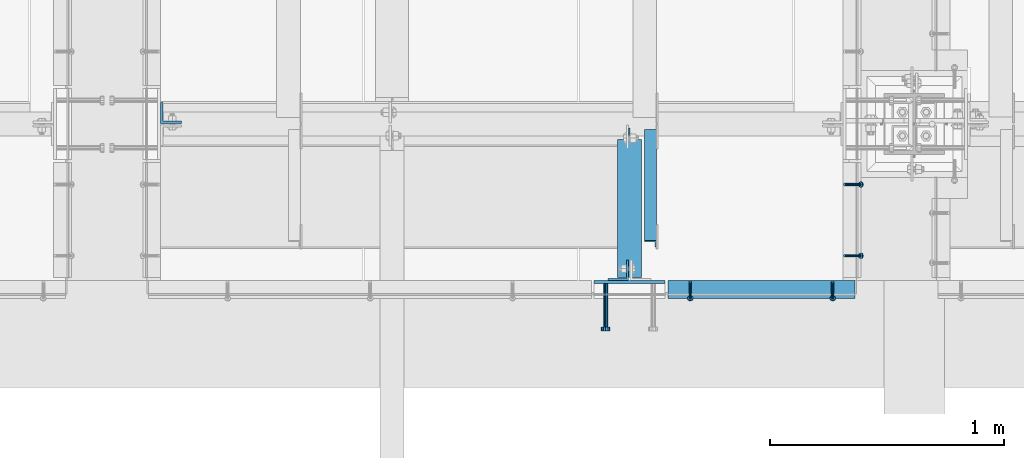
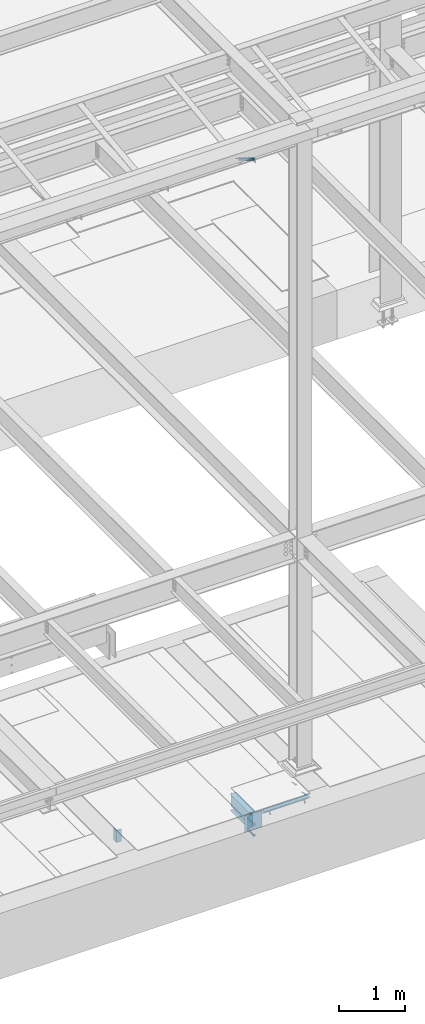
# One storey, part 2049 of 3843: 7 beams, 5 members, 6 elements without a shape of their own.
"""IFC2X3 building model written with IfcOpenShell, lengths in millimetres."""

from ifc_helpers import new_model, si_unit, frame, origin_with_axes, place, context, subcontext, project, spatial, faceted_brep, material, type_object, element, aggregate, save


model = new_model("IFC2X3")

# Units and contexts
model_context = context("Model", 3, precision=1e-05, world=origin_with_axes())
body_context = subcontext(model_context, "Body", "Model", "MODEL_VIEW")
ifc_project = project(units=[si_unit("LENGTHUNIT", "METRE", prefix="MILLI"), si_unit("AREAUNIT", "SQUARE_METRE"), si_unit("VOLUMEUNIT", "CUBIC_METRE"), si_unit("MASSUNIT", "GRAM", prefix="KILO"), si_unit("TIMEUNIT", "SECOND"), si_unit("PLANEANGLEUNIT", "RADIAN"), si_unit("SOLIDANGLEUNIT", "STERADIAN"), si_unit("THERMODYNAMICTEMPERATUREUNIT", "DEGREE_CELSIUS"), si_unit("LUMINOUSINTENSITYUNIT", "LUMEN")], contexts=[model_context])

# Site, building, storey
site_placement = place(None, origin_with_axes())
site = spatial("IfcSite", under=ifc_project, at=site_placement, CompositionType="ELEMENT")
building_placement = place(site_placement, origin_with_axes())
building = spatial("IfcBuilding", under=site, at=building_placement, Name="Undefined", CompositionType="ELEMENT")
storey_placement = place(building_placement, origin_with_axes())
storey = spatial("IfcBuildingStorey", under=building, at=storey_placement, Name="Undefined", CompositionType="ELEMENT", Elevation=0.0)

# Assembly, members
assembly_1_placement = place(storey_placement, origin_with_axes())
assembly_1 = element("IfcElementAssembly", 1, at=assembly_1_placement, inside=storey, Name="ANGLE", AssemblyPlace="NOTDEFINED", PredefinedType="RIGID_FRAME")
ifc_material_1 = material(Name="STEEL/A108")
member_type_1 = type_object("IfcMemberType", PredefinedType="NOTDEFINED")
member_1_placement = place(assembly_1_placement, frame((62337.9500047469, 14739.9375439544, 30422.8500045777), z_axis=(0.0, 1.0, 0.0), x_axis=(0.707106781186548, 0.0, -0.707106781186548)))
member_1 = element("IfcMember", 2, at=member_1_placement, type_object=member_type_1, material=ifc_material_1, Name="HEADED STUD ANCHOR", context=body_context, shape_type="Brep", body=[
    faceted_brep([(7.27595761418343e-12, -3.18000006675175, 5.5), (0.0, -5.49999999998363, 3.1800000667572), (94.4879985803855, -5.50000000011278, 3.1800000667572), (94.4879985803782, -3.18000006687362, 5.5), (0.0, -6.3499999046162, 0.0), (94.4879985803855, -6.34999990474535, 0.0), (0.0, -5.49999999998363, -3.1800000667572), (94.4879985803855, -5.50000000011278, -3.1800000667572), (7.27595761418343e-12, -3.18000006675175, -5.5), (94.4879985803782, -3.18000006687362, -5.5), (7.27595761418343e-12, -1.81898940354586e-12, -6.34999990463257), (94.4879985803782, -1.20053300634027e-10, -6.34999990463257), (0.0, 3.18000006675175, -5.5), (94.4879985803709, 3.18000006663351, -5.5), (7.27595761418343e-12, 5.49999999998363, -3.1800000667572), (94.4879985803709, 5.49999999987267, -3.1800000667572), (7.27595761418343e-12, 6.3499999046162, 0.0), (94.4879985803673, 6.34999990450706, 0.0), (7.27595761418343e-12, 5.49999999998363, 3.1800000667572), (94.4879985803709, 5.49999999987267, 3.1800000667572), (0.0, 3.18000006675175, 5.5), (94.4879985803709, 3.18000006663351, 5.5), (7.27595761418343e-12, -1.81898940354586e-12, 6.34999990463257), (94.4879985803782, -1.20053300634027e-10, 6.34999990463257), (96.5199985498621, -10.9899997712273, 6.34999990463257), (96.5199985498548, -6.34000015270249, 10.9899997711182), (96.5199985498621, -12.6999998093743, 0.0), (96.5199985498621, -10.9899997712273, -6.34999990463257), (96.5199985498548, -6.34000015270249, -10.9899997711182), (96.5199985498475, -1.21872290037572e-10, -12.6899995803833), (96.5199985498402, 6.34000015245874, -10.9899997711182), (96.519998549833, 10.9899997709817, -6.34999990463257), (96.519998549833, 12.6999998091305, 0.0), (96.519998549833, 10.9899997709817, 6.34999990463257), (96.5199985498402, 6.34000015245874, 10.9899997711182), (96.5199985498475, -1.21872290037572e-10, 12.6899995803833), (101.599998473539, -10.9899997712328, 6.34999990463257), (101.599998473532, -6.34000015270976, 10.9899997711182), (101.599998473539, -12.6999998093797, 0.0), (101.599998473539, -10.9899997712328, -6.34999990463257), (101.599998473532, -6.34000015270976, -10.9899997711182), (101.599998473524, -1.29148247651756e-10, -12.6899995803833), (101.599998473517, 6.34000015245329, -10.9899997711182), (101.59999847351, 10.9899997709763, -6.34999990463257), (101.599998473503, 12.6999998091196, 0.0), (101.59999847351, 10.9899997709763, 6.34999990463257), (101.599998473517, 6.34000015245329, 10.9899997711182), (101.599998473524, -1.29148247651756e-10, 12.6899995803833)], [[[0, 1, 2, 3]], [[1, 4, 5, 2]], [[4, 6, 7, 5]], [[6, 8, 9, 7]], [[8, 10, 11, 9]], [[10, 12, 13, 11]], [[12, 14, 15, 13]], [[14, 16, 17, 15]], [[16, 18, 19, 17]], [[18, 20, 21, 19]], [[20, 22, 23, 21]], [[22, 0, 3, 23]], [[22, 20, 18, 16, 14, 12, 10, 8, 6, 4, 1, 0]], [[3, 2, 24, 25]], [[2, 5, 26, 24]], [[5, 7, 27, 26]], [[7, 9, 28, 27]], [[9, 11, 29, 28]], [[11, 13, 30, 29]], [[13, 15, 31, 30]], [[15, 17, 32, 31]], [[17, 19, 33, 32]], [[19, 21, 34, 33]], [[21, 23, 35, 34]], [[23, 3, 25, 35]], [[25, 24, 36, 37]], [[24, 26, 38, 36]], [[26, 27, 39, 38]], [[27, 28, 40, 39]], [[28, 29, 41, 40]], [[29, 30, 42, 41]], [[30, 31, 43, 42]], [[31, 32, 44, 43]], [[32, 33, 45, 44]], [[33, 34, 46, 45]], [[34, 35, 47, 46]], [[35, 25, 37, 47]], [[38, 39, 40, 41, 42, 43, 44, 45, 46, 47, 37, 36]]]),
])
member_2_placement = place(assembly_1_placement, frame((62337.9500047469, 14435.1375439544, 30422.8500045777), z_axis=(0.0, 1.0, 0.0), x_axis=(0.707106781186548, 0.0, -0.707106781186548)))
member_2 = element("IfcMember", 3, at=member_2_placement, type_object=member_type_1, material=ifc_material_1, Name="HEADED STUD ANCHOR", context=body_context, shape_type="Brep", body=[
    faceted_brep([(7.27595761418343e-12, -3.18000006675175, 5.5), (0.0, -5.49999999998363, 3.1800000667572), (94.4879985803855, -5.50000000011278, 3.1800000667572), (94.4879985803782, -3.18000006687362, 5.5), (0.0, -6.3499999046162, 0.0), (94.4879985803855, -6.34999990474535, 0.0), (0.0, -5.49999999998363, -3.1800000667572), (94.4879985803855, -5.50000000011278, -3.1800000667572), (7.27595761418343e-12, -3.18000006675175, -5.5), (94.4879985803782, -3.18000006687362, -5.5), (7.27595761418343e-12, -1.81898940354586e-12, -6.34999990463257), (94.4879985803782, -1.20053300634027e-10, -6.34999990463257), (0.0, 3.18000006675175, -5.5), (94.4879985803709, 3.18000006663351, -5.5), (7.27595761418343e-12, 5.49999999998363, -3.1800000667572), (94.4879985803709, 5.49999999987267, -3.1800000667572), (7.27595761418343e-12, 6.3499999046162, 0.0), (94.4879985803673, 6.34999990450706, 0.0), (7.27595761418343e-12, 5.49999999998363, 3.1800000667572), (94.4879985803709, 5.49999999987267, 3.1800000667572), (0.0, 3.18000006675175, 5.5), (94.4879985803709, 3.18000006663351, 5.5), (7.27595761418343e-12, -1.81898940354586e-12, 6.34999990463257), (94.4879985803782, -1.20053300634027e-10, 6.34999990463257), (96.5199985498621, -10.9899997712273, 6.34999990463257), (96.5199985498548, -6.34000015270249, 10.9899997711182), (96.5199985498621, -12.6999998093743, 0.0), (96.5199985498621, -10.9899997712273, -6.34999990463257), (96.5199985498548, -6.34000015270249, -10.9899997711182), (96.5199985498475, -1.21872290037572e-10, -12.6899995803833), (96.5199985498402, 6.34000015245874, -10.9899997711182), (96.519998549833, 10.9899997709817, -6.34999990463257), (96.519998549833, 12.6999998091305, 0.0), (96.519998549833, 10.9899997709817, 6.34999990463257), (96.5199985498402, 6.34000015245874, 10.9899997711182), (96.5199985498475, -1.21872290037572e-10, 12.6899995803833), (101.599998473539, -10.9899997712328, 6.34999990463257), (101.599998473532, -6.34000015270976, 10.9899997711182), (101.599998473539, -12.6999998093797, 0.0), (101.599998473539, -10.9899997712328, -6.34999990463257), (101.599998473532, -6.34000015270976, -10.9899997711182), (101.599998473524, -1.29148247651756e-10, -12.6899995803833), (101.599998473517, 6.34000015245329, -10.9899997711182), (101.59999847351, 10.9899997709763, -6.34999990463257), (101.599998473503, 12.6999998091196, 0.0), (101.59999847351, 10.9899997709763, 6.34999990463257), (101.599998473517, 6.34000015245329, 10.9899997711182), (101.599998473524, -1.29148247651756e-10, 12.6899995803833)], [[[0, 1, 2, 3]], [[1, 4, 5, 2]], [[4, 6, 7, 5]], [[6, 8, 9, 7]], [[8, 10, 11, 9]], [[10, 12, 13, 11]], [[12, 14, 15, 13]], [[14, 16, 17, 15]], [[16, 18, 19, 17]], [[18, 20, 21, 19]], [[20, 22, 23, 21]], [[22, 0, 3, 23]], [[22, 20, 18, 16, 14, 12, 10, 8, 6, 4, 1, 0]], [[3, 2, 24, 25]], [[2, 5, 26, 24]], [[5, 7, 27, 26]], [[7, 9, 28, 27]], [[9, 11, 29, 28]], [[11, 13, 30, 29]], [[13, 15, 31, 30]], [[15, 17, 32, 31]], [[17, 19, 33, 32]], [[19, 21, 34, 33]], [[21, 23, 35, 34]], [[23, 3, 25, 35]], [[25, 24, 36, 37]], [[24, 26, 38, 36]], [[26, 27, 39, 38]], [[27, 28, 40, 39]], [[28, 29, 41, 40]], [[29, 30, 42, 41]], [[30, 31, 43, 42]], [[31, 32, 44, 43]], [[32, 33, 45, 44]], [[33, 34, 46, 45]], [[34, 35, 47, 46]], [[35, 25, 37, 47]], [[38, 39, 40, 41, 42, 43, 44, 45, 46, 47, 37, 36]]]),
])
aggregate(assembly_1, [member_1, member_2])

assembly_2_placement = place(storey_placement, origin_with_axes())
assembly_2 = element("IfcElementAssembly", 4, at=assembly_2_placement, inside=storey, Name="ANGLE", AssemblyPlace="NOTDEFINED", PredefinedType="RIGID_FRAME")
member_3_placement = place(assembly_2_placement, frame((62287.1500073438, 14322.4247582801, 30422.8500024177), z_axis=(1.0, 0.0, 0.0), x_axis=(0.0, -0.707106781186548, -0.707106781186548)))
member_3 = element("IfcMember", 5, at=member_3_placement, type_object=member_type_1, material=ifc_material_1, Name="HEADED STUD ANCHOR", context=body_context, shape_type="Brep", body=[
    faceted_brep([(7.27595761418343e-12, -3.18000006675175, 5.5), (0.0, -5.49999999998363, 3.1800000667572), (94.4879985803855, -5.50000000011278, 3.1800000667572), (94.4879985803782, -3.18000006687362, 5.5), (0.0, -6.3499999046162, 0.0), (94.4879985803855, -6.34999990474535, 0.0), (0.0, -5.49999999998363, -3.1800000667572), (94.4879985803855, -5.50000000011278, -3.1800000667572), (7.27595761418343e-12, -3.18000006675175, -5.5), (94.4879985803782, -3.18000006687362, -5.5), (7.27595761418343e-12, -1.81898940354586e-12, -6.34999990463257), (94.4879985803782, -1.20053300634027e-10, -6.34999990463257), (0.0, 3.18000006675175, -5.5), (94.4879985803709, 3.18000006663351, -5.5), (7.27595761418343e-12, 5.49999999998363, -3.1800000667572), (94.4879985803709, 5.49999999987267, -3.1800000667572), (7.27595761418343e-12, 6.3499999046162, 0.0), (94.4879985803673, 6.34999990450706, 0.0), (7.27595761418343e-12, 5.49999999998363, 3.1800000667572), (94.4879985803709, 5.49999999987267, 3.1800000667572), (0.0, 3.18000006675175, 5.5), (94.4879985803709, 3.18000006663351, 5.5), (7.27595761418343e-12, -1.81898940354586e-12, 6.34999990463257), (94.4879985803782, -1.20053300634027e-10, 6.34999990463257), (96.5199985498621, -10.9899997712273, 6.34999990463257), (96.5199985498548, -6.34000015270249, 10.9899997711182), (96.5199985498621, -12.6999998093743, 0.0), (96.5199985498621, -10.9899997712273, -6.34999990463257), (96.5199985498548, -6.34000015270249, -10.9899997711182), (96.5199985498475, -1.21872290037572e-10, -12.6899995803833), (96.5199985498402, 6.34000015245874, -10.9899997711182), (96.519998549833, 10.9899997709817, -6.34999990463257), (96.519998549833, 12.6999998091305, 0.0), (96.519998549833, 10.9899997709817, 6.34999990463257), (96.5199985498402, 6.34000015245874, 10.9899997711182), (96.5199985498475, -1.21872290037572e-10, 12.6899995803833), (101.599998473539, -10.9899997712328, 6.34999990463257), (101.599998473532, -6.34000015270976, 10.9899997711182), (101.599998473539, -12.6999998093797, 0.0), (101.599998473539, -10.9899997712328, -6.34999990463257), (101.599998473532, -6.34000015270976, -10.9899997711182), (101.599998473524, -1.29148247651756e-10, -12.6899995803833), (101.599998473517, 6.34000015245329, -10.9899997711182), (101.59999847351, 10.9899997709763, -6.34999990463257), (101.599998473503, 12.6999998091196, 0.0), (101.59999847351, 10.9899997709763, 6.34999990463257), (101.599998473517, 6.34000015245329, 10.9899997711182), (101.599998473524, -1.29148247651756e-10, 12.6899995803833)], [[[0, 1, 2, 3]], [[1, 4, 5, 2]], [[4, 6, 7, 5]], [[6, 8, 9, 7]], [[8, 10, 11, 9]], [[10, 12, 13, 11]], [[12, 14, 15, 13]], [[14, 16, 17, 15]], [[16, 18, 19, 17]], [[18, 20, 21, 19]], [[20, 22, 23, 21]], [[22, 0, 3, 23]], [[22, 20, 18, 16, 14, 12, 10, 8, 6, 4, 1, 0]], [[3, 2, 24, 25]], [[2, 5, 26, 24]], [[5, 7, 27, 26]], [[7, 9, 28, 27]], [[9, 11, 29, 28]], [[11, 13, 30, 29]], [[13, 15, 31, 30]], [[15, 17, 32, 31]], [[17, 19, 33, 32]], [[19, 21, 34, 33]], [[21, 23, 35, 34]], [[23, 3, 25, 35]], [[25, 24, 36, 37]], [[24, 26, 38, 36]], [[26, 27, 39, 38]], [[27, 28, 40, 39]], [[28, 29, 41, 40]], [[29, 30, 42, 41]], [[30, 31, 43, 42]], [[31, 32, 44, 43]], [[32, 33, 45, 44]], [[33, 34, 46, 45]], [[34, 35, 47, 46]], [[35, 25, 37, 47]], [[38, 39, 40, 41, 42, 43, 44, 45, 46, 47, 37, 36]]]),
])
member_4_placement = place(assembly_2_placement, frame((61677.5500073438, 14322.4247582801, 30422.8500024177), z_axis=(1.0, 0.0, 0.0), x_axis=(0.0, -0.707106781186548, -0.707106781186548)))
member_4 = element("IfcMember", 6, at=member_4_placement, type_object=member_type_1, material=ifc_material_1, Name="HEADED STUD ANCHOR", context=body_context, shape_type="Brep", body=[
    faceted_brep([(7.27595761418343e-12, -3.18000006675175, 5.5), (0.0, -5.49999999998363, 3.1800000667572), (94.4879985803855, -5.50000000011278, 3.1800000667572), (94.4879985803782, -3.18000006687362, 5.5), (0.0, -6.3499999046162, 0.0), (94.4879985803855, -6.34999990474535, 0.0), (0.0, -5.49999999998363, -3.1800000667572), (94.4879985803855, -5.50000000011278, -3.1800000667572), (7.27595761418343e-12, -3.18000006675175, -5.5), (94.4879985803782, -3.18000006687362, -5.5), (7.27595761418343e-12, -1.81898940354586e-12, -6.34999990463257), (94.4879985803782, -1.20053300634027e-10, -6.34999990463257), (0.0, 3.18000006675175, -5.5), (94.4879985803709, 3.18000006663351, -5.5), (7.27595761418343e-12, 5.49999999998363, -3.1800000667572), (94.4879985803709, 5.49999999987267, -3.1800000667572), (7.27595761418343e-12, 6.3499999046162, 0.0), (94.4879985803673, 6.34999990450706, 0.0), (7.27595761418343e-12, 5.49999999998363, 3.1800000667572), (94.4879985803709, 5.49999999987267, 3.1800000667572), (0.0, 3.18000006675175, 5.5), (94.4879985803709, 3.18000006663351, 5.5), (7.27595761418343e-12, -1.81898940354586e-12, 6.34999990463257), (94.4879985803782, -1.20053300634027e-10, 6.34999990463257), (96.5199985498621, -10.9899997712273, 6.34999990463257), (96.5199985498548, -6.34000015270249, 10.9899997711182), (96.5199985498621, -12.6999998093743, 0.0), (96.5199985498621, -10.9899997712273, -6.34999990463257), (96.5199985498548, -6.34000015270249, -10.9899997711182), (96.5199985498475, -1.21872290037572e-10, -12.6899995803833), (96.5199985498402, 6.34000015245874, -10.9899997711182), (96.519998549833, 10.9899997709817, -6.34999990463257), (96.519998549833, 12.6999998091305, 0.0), (96.519998549833, 10.9899997709817, 6.34999990463257), (96.5199985498402, 6.34000015245874, 10.9899997711182), (96.5199985498475, -1.21872290037572e-10, 12.6899995803833), (101.599998473539, -10.9899997712328, 6.34999990463257), (101.599998473532, -6.34000015270976, 10.9899997711182), (101.599998473539, -12.6999998093797, 0.0), (101.599998473539, -10.9899997712328, -6.34999990463257), (101.599998473532, -6.34000015270976, -10.9899997711182), (101.599998473524, -1.29148247651756e-10, -12.6899995803833), (101.599998473517, 6.34000015245329, -10.9899997711182), (101.59999847351, 10.9899997709763, -6.34999990463257), (101.599998473503, 12.6999998091196, 0.0), (101.59999847351, 10.9899997709763, 6.34999990463257), (101.599998473517, 6.34000015245329, 10.9899997711182), (101.599998473524, -1.29148247651756e-10, 12.6899995803833)], [[[0, 1, 2, 3]], [[1, 4, 5, 2]], [[4, 6, 7, 5]], [[6, 8, 9, 7]], [[8, 10, 11, 9]], [[10, 12, 13, 11]], [[12, 14, 15, 13]], [[14, 16, 17, 15]], [[16, 18, 19, 17]], [[18, 20, 21, 19]], [[20, 22, 23, 21]], [[22, 0, 3, 23]], [[22, 20, 18, 16, 14, 12, 10, 8, 6, 4, 1, 0]], [[3, 2, 24, 25]], [[2, 5, 26, 24]], [[5, 7, 27, 26]], [[7, 9, 28, 27]], [[9, 11, 29, 28]], [[11, 13, 30, 29]], [[13, 15, 31, 30]], [[15, 17, 32, 31]], [[17, 19, 33, 32]], [[19, 21, 34, 33]], [[21, 23, 35, 34]], [[23, 3, 25, 35]], [[25, 24, 36, 37]], [[24, 26, 38, 36]], [[26, 27, 39, 38]], [[27, 28, 40, 39]], [[28, 29, 41, 40]], [[29, 30, 42, 41]], [[30, 31, 43, 42]], [[31, 32, 44, 43]], [[32, 33, 45, 44]], [[33, 34, 46, 45]], [[34, 35, 47, 46]], [[35, 25, 37, 47]], [[38, 39, 40, 41, 42, 43, 44, 45, 46, 47, 37, 36]]]),
])

# Assembly, beam
assembly_3_placement = place(storey_placement, origin_with_axes())
assembly_3 = element("IfcElementAssembly", 7, at=assembly_3_placement, inside=storey, Name="EMBED PLATE", AssemblyPlace="NOTDEFINED", PredefinedType="RIGID_FRAME")
ifc_material_2 = material(Name="STEEL/A36")
beam_type_1 = type_object("IfcBeamType", PredefinedType="NOTDEFINED")
beam_1_placement = place(assembly_3_placement, frame((61417.2, 14322.4250030517, 30422.85), z_axis=(-1.0, 0.0, 0.0), x_axis=(0.0, 0.0, -1.0)))
beam_1 = element("IfcBeam", 8, at=beam_1_placement, type_object=beam_type_1, material=ifc_material_2, Name="EMBED PLATE", context=body_context, shape_type="Brep", body=[
    faceted_brep([(-1.0550138540566e-10, 6.34999999999854, -152.400000000664), (1.0550138540566e-10, 6.34999999999854, 152.400000000656), (304.799999999999, 6.34999999999854, 152.400000000001), (304.799999999999, 6.34999999999854, -152.400000000001), (1.0550138540566e-10, -6.34999999999854, 152.400000000656), (304.799999999999, -6.34999999999854, 152.400000000001), (-1.0550138540566e-10, -6.34999999999854, -152.400000000664), (304.799999999999, -6.34999999999854, -152.400000000001)], [[[0, 1, 2, 3]], [[1, 4, 5, 2]], [[4, 6, 7, 5]], [[6, 0, 3, 7]], [[5, 7, 3, 2]], [[6, 4, 1, 0]]]),
])

# Assembly, member
assembly_4_placement = place(storey_placement, origin_with_axes())
assembly_4 = element("IfcElementAssembly", 9, at=assembly_4_placement, inside=storey, Name="ANGLE", AssemblyPlace="NOTDEFINED", PredefinedType="RIGID_FRAME")
ifc_material_3 = material(Name="STEEL/A572-50")
member_type_2 = type_object("IfcMemberType", Name="L2X2X1/4", PredefinedType="NOTDEFINED")
member_5_placement = place(assembly_4_placement, frame((61507.6875, 14962.4615149769, 42136.6100587905), z_axis=(-1.0, 0.0, 0.0), x_axis=(0.0, -0.851012521472712, 0.5251453972917)))
member_5 = element("IfcMember", 10, at=member_5_placement, type_object=member_type_2, material=ifc_material_3, Name="ANGLE", ObjectType="L2X2X1/4", context=body_context, shape_type="Brep", body=[
    faceted_brep([(0.0, 25.4000000000015, -25.4000000000015), (0.0, 25.4000000000015, 25.4000000000015), (558.799999999297, 25.3999999986918, 25.3999999999942), (558.799999999297, 25.3999999986918, -25.3999999999942), (0.0, 19.0500000000029, 25.4000000000015), (558.799999999297, 19.049999998686, 25.3999999999942), (0.0, 19.0500000000029, -19.0499999999993), (558.799999999297, 19.049999998686, -19.0500000000029), (0.0, -25.4000000000015, -19.0499999999993), (558.799999999281, -25.4000000013912, -19.0500000000029), (0.0, -25.4000000000015, -25.4000000000015), (558.799999999281, -25.4000000013912, -25.3999999999942)], [[[0, 1, 2, 3]], [[1, 4, 5, 2]], [[4, 6, 7, 5]], [[6, 8, 9, 7]], [[8, 10, 11, 9]], [[10, 0, 3, 11]], [[5, 7, 9, 11, 3, 2]], [[10, 8, 6, 4, 1, 0]]]),
])
aggregate(assembly_4, [member_5])

# Beam
beam_type_2 = type_object("IfcBeamType", Name="L3X3X1/4", PredefinedType="NOTDEFINED")
beam_2_placement = place(assembly_2_placement, frame((62382.4000024632, 14290.6746877398, 30391.1000030518), z_axis=(0.0, 0.0, -1.0), x_axis=(-1.0, 0.0, 0.0)))
beam_2 = element("IfcBeam", 11, at=beam_2_placement, type_object=beam_type_2, material=ifc_material_2, Name="ANGLE", ObjectType="L3X3X1/4", context=body_context, shape_type="Brep", body=[
    faceted_brep([(0.0, 38.0999999999985, -38.0999999999985), (0.0, 38.0999999999985, 38.0999999999985), (800.10003051789, 38.0999999998003, 38.0999999999985), (800.10003051789, 38.0999999998003, -38.0999999999985), (0.0, 31.75, 38.0999999999985), (800.100030517875, 31.7499999997999, 38.0999999999985), (0.0, 31.75, -31.75), (800.100030517875, 31.7499999997999, -31.75), (0.0, -38.0999999999985, -31.75), (800.100030517729, -38.1000000002023, -31.75), (0.0, -38.0999999999985, -38.0999999999985), (800.100030517729, -38.1000000002023, -38.0999999999985)], [[[0, 1, 2, 3]], [[1, 4, 5, 2]], [[4, 6, 7, 5]], [[6, 8, 9, 7]], [[8, 10, 11, 9]], [[10, 0, 3, 11]], [[5, 7, 9, 11, 3, 2]], [[10, 8, 6, 4, 1, 0]]]),
])

aggregate(assembly_2, [member_3, member_4, beam_2])

# Assembly, beam
assembly_5_placement = place(storey_placement, origin_with_axes())
assembly_5 = element("IfcElementAssembly", 12, at=assembly_5_placement, inside=storey, Name="BEAM", AssemblyPlace="NOTDEFINED", PredefinedType="RIGID_FRAME")
beam_type_3 = type_object("IfcBeamType", Name="L3-1/2X3-1/2X3/8", PredefinedType="NOTDEFINED")
beam_3_placement = place(assembly_5_placement, frame((61369.575, 14373.2250030517, 30391.1), z_axis=(-1.0, 0.0, 0.0), x_axis=(0.0, 0.0, -1.0)))
beam_3 = element("IfcBeam", 13, at=beam_3_placement, type_object=beam_type_3, material=ifc_material_2, Name="ANGLE", ObjectType="L3-1/2X3-1/2X3/8", context=body_context, shape_type="Brep", body=[
    faceted_brep([(-3.63797880709171e-12, 44.4499999999971, -44.4500000000007), (-3.63797880709171e-12, 44.4499999999971, 44.4500000000007), (228.600000000006, 44.4499999999971, 44.4500000000007), (228.600000000006, 44.4499999999971, -44.4500000000007), (0.0, 34.9250000000029, 44.4500000000007), (228.600000000006, 34.9250000000029, 44.4500000000007), (0.0, 34.9250000000029, -34.9250000000029), (228.600000000006, 34.9250000000029, -34.9249999999993), (0.0, -44.4499999999971, -34.9249999999993), (228.600000000006, -44.4499999999971, -34.9249999999993), (3.63797880709171e-12, -44.4499999999971, -44.4500000000007), (228.600000000006, -44.4499999999971, -44.4500000000007)], [[[0, 1, 2, 3]], [[1, 4, 5, 2]], [[4, 6, 7, 5]], [[6, 8, 9, 7]], [[8, 10, 11, 9]], [[10, 0, 3, 11]], [[5, 7, 9, 11, 3, 2]], [[10, 8, 6, 4, 1, 0]]]),
])

assembly_6_placement = place(storey_placement, origin_with_axes())
assembly_6 = element("IfcElementAssembly", 14, at=assembly_6_placement, inside=storey, Name="BEAM", AssemblyPlace="NOTDEFINED", PredefinedType="RIGID_FRAME")
beam_4_placement = place(assembly_6_placement, frame((59455.0500030518, 15046.325, 30391.1), z_axis=(0.0, 1.0, 0.0), x_axis=(0.0, 0.0, -1.0)))
beam_4 = element("IfcBeam", 15, at=beam_4_placement, type_object=beam_type_3, material=ifc_material_2, Name="ANGLE", ObjectType="L3-1/2X3-1/2X3/8", context=body_context, shape_type="Brep", body=[
    faceted_brep([(-3.63797880709171e-12, 44.4499999999971, -44.4500000000007), (-3.63797880709171e-12, 44.4499999999971, 44.4500000000007), (228.600000000006, 44.4499999999971, 44.4500000000007), (228.600000000006, 44.4499999999971, -44.4500000000007), (0.0, 34.9250000000029, 44.4500000000007), (228.600000000006, 34.9250000000029, 44.4500000000007), (0.0, 34.9250000000029, -34.9250000000029), (228.600000000006, 34.9250000000029, -34.9249999999993), (0.0, -44.4499999999971, -34.9249999999993), (228.600000000006, -44.4499999999971, -34.9249999999993), (3.63797880709171e-12, -44.4499999999971, -44.4500000000007), (228.600000000006, -44.4499999999971, -44.4500000000007)], [[[0, 1, 2, 3]], [[1, 4, 5, 2]], [[4, 6, 7, 5]], [[6, 8, 9, 7]], [[8, 10, 11, 9]], [[10, 0, 3, 11]], [[5, 7, 9, 11, 3, 2]], [[10, 8, 6, 4, 1, 0]]]),
])
aggregate(assembly_6, [beam_4])

# Beam
beam_type_4 = type_object("IfcBeamType", PredefinedType="NOTDEFINED")
beam_5_placement = place(assembly_3_placement, frame((61315.6, 14316.0750030518, 30372.05), z_axis=(1.0, 0.0, 0.0), x_axis=(0.0, -1.0, 0.0)))
beam_5 = element("IfcBeam", 16, at=beam_5_placement, type_object=beam_type_4, material=ifc_material_2, Name="PLATE", context=body_context, shape_type="Brep", body=[
    faceted_brep([(0.0, -9.52000045776367, 0.0), (0.0, -8.25, -4.76000022888184), (184.912000000004, -8.25, -4.76000022888184), (184.912000000004, -9.52000045776367, 0.0), (0.0, -4.76000022888184, -8.25), (184.912000000004, -4.76000022888184, -8.25), (0.0, 0.0, -9.52000045776367), (184.912000000004, 0.0, -9.52000045776367), (0.0, 4.76000022888184, -8.25), (184.912000000004, 4.76000022888184, -8.25), (0.0, 8.25, -4.76000022888184), (184.912000000004, 8.25, -4.76000022888184), (0.0, 9.52000045776367, 0.0), (184.912000000004, 9.52000045776367, 0.0), (0.0, 8.25, 4.76000022888184), (184.912000000004, 8.25, 4.76000022888184), (0.0, 4.76000022888184, 8.25), (184.912000000004, 4.76000022888184, 8.25), (0.0, 0.0, 9.52000045776367), (184.912000000004, 0.0, 9.52000045776367), (0.0, -4.76000022888184, 8.25), (184.912000000004, -4.76000022888184, 8.25), (0.0, -8.25, 4.76000022888184), (184.912000000004, -8.25, 4.76000022888184), (186.944000000003, -16.5, -9.52000045776367), (186.944000000003, -19.0499992370605, 0.0), (186.944000000003, -9.52000045776367, -16.5), (186.944000000003, 0.0, -19.0499992370605), (186.944000000003, 9.52000045776367, -16.5), (186.944000000003, 16.5, -9.52000045776367), (186.944000000003, 19.0499992370605, 0.0), (186.944000000003, 16.5, 9.52000045776367), (186.944000000003, 9.52000045776367, 16.5), (186.944000000003, 0.0, 19.0499992370605), (186.944000000003, -9.52000045776367, 16.5), (186.944000000003, -16.5, 9.52000045776367), (203.199999999997, -16.5, -9.52000045776367), (203.199999999997, -19.0499992370605, 0.0), (203.199999999997, -9.52000045776367, -16.5), (203.199999999997, 0.0, -19.0499992370605), (203.199999999997, 9.52000045776367, -16.5), (203.199999999997, 16.5, -9.52000045776367), (203.199999999997, 19.0499992370605, 0.0), (203.199999999997, 16.5, 9.52000045776367), (203.199999999997, 9.52000045776367, 16.5), (203.199999999997, 0.0, 19.0499992370605), (203.199999999997, -9.52000045776367, 16.5), (203.199999999997, -16.5, 9.52000045776367)], [[[0, 1, 2, 3]], [[1, 4, 5, 2]], [[4, 6, 7, 5]], [[6, 8, 9, 7]], [[8, 10, 11, 9]], [[10, 12, 13, 11]], [[12, 14, 15, 13]], [[14, 16, 17, 15]], [[16, 18, 19, 17]], [[18, 20, 21, 19]], [[20, 22, 23, 21]], [[22, 0, 3, 23]], [[22, 20, 18, 16, 14, 12, 10, 8, 6, 4, 1, 0]], [[3, 2, 24, 25]], [[2, 5, 26, 24]], [[5, 7, 27, 26]], [[7, 9, 28, 27]], [[9, 11, 29, 28]], [[11, 13, 30, 29]], [[13, 15, 31, 30]], [[15, 17, 32, 31]], [[17, 19, 33, 32]], [[19, 21, 34, 33]], [[21, 23, 35, 34]], [[23, 3, 25, 35]], [[25, 24, 36, 37]], [[24, 26, 38, 36]], [[26, 27, 39, 38]], [[27, 28, 40, 39]], [[28, 29, 41, 40]], [[29, 30, 42, 41]], [[30, 31, 43, 42]], [[31, 32, 44, 43]], [[32, 33, 45, 44]], [[33, 34, 46, 45]], [[34, 35, 47, 46]], [[35, 25, 37, 47]], [[38, 39, 40, 41, 42, 43, 44, 45, 46, 47, 37, 36]]]),
])

beam_6_placement = place(assembly_3_placement, frame((61315.6, 14316.0750030518, 30168.85), z_axis=(1.0, 0.0, 0.0), x_axis=(0.0, -1.0, 0.0)))
beam_6 = element("IfcBeam", 17, at=beam_6_placement, type_object=beam_type_4, material=ifc_material_1, Name="HEADED STUD ANCHOR", context=body_context, shape_type="Brep", body=[
    faceted_brep([(0.0, -9.52000045776367, 0.0), (0.0, -8.25, -4.76000022888184), (184.912000000004, -8.25, -4.76000022888184), (184.912000000004, -9.52000045776367, 0.0), (0.0, -4.76000022888184, -8.25), (184.912000000004, -4.76000022888184, -8.25), (0.0, 0.0, -9.52000045776367), (184.912000000004, 0.0, -9.52000045776367), (0.0, 4.76000022888184, -8.25), (184.912000000004, 4.76000022888184, -8.25), (0.0, 8.25, -4.76000022888184), (184.912000000004, 8.25, -4.76000022888184), (0.0, 9.52000045776367, 0.0), (184.912000000004, 9.52000045776367, 0.0), (0.0, 8.25, 4.76000022888184), (184.912000000004, 8.25, 4.76000022888184), (0.0, 4.76000022888184, 8.25), (184.912000000004, 4.76000022888184, 8.25), (0.0, 0.0, 9.52000045776367), (184.912000000004, 0.0, 9.52000045776367), (0.0, -4.76000022888184, 8.25), (184.912000000004, -4.76000022888184, 8.25), (0.0, -8.25, 4.76000022888184), (184.912000000004, -8.25, 4.76000022888184), (186.944000000003, -16.5, -9.52000045776367), (186.944000000003, -19.0499992370605, 0.0), (186.944000000003, -9.52000045776367, -16.5), (186.944000000003, 0.0, -19.0499992370605), (186.944000000003, 9.52000045776367, -16.5), (186.944000000003, 16.5, -9.52000045776367), (186.944000000003, 19.0499992370605, 0.0), (186.944000000003, 16.5, 9.52000045776367), (186.944000000003, 9.52000045776367, 16.5), (186.944000000003, 0.0, 19.0499992370605), (186.944000000003, -9.52000045776367, 16.5), (186.944000000003, -16.5, 9.52000045776367), (203.199999999997, -16.5, -9.52000045776367), (203.199999999997, -19.0499992370605, 0.0), (203.199999999997, -9.52000045776367, -16.5), (203.199999999997, 0.0, -19.0499992370605), (203.199999999997, 9.52000045776367, -16.5), (203.199999999997, 16.5, -9.52000045776367), (203.199999999997, 19.0499992370605, 0.0), (203.199999999997, 16.5, 9.52000045776367), (203.199999999997, 9.52000045776367, 16.5), (203.199999999997, 0.0, 19.0499992370605), (203.199999999997, -9.52000045776367, 16.5), (203.199999999997, -16.5, 9.52000045776367)], [[[0, 1, 2, 3]], [[1, 4, 5, 2]], [[4, 6, 7, 5]], [[6, 8, 9, 7]], [[8, 10, 11, 9]], [[10, 12, 13, 11]], [[12, 14, 15, 13]], [[14, 16, 17, 15]], [[16, 18, 19, 17]], [[18, 20, 21, 19]], [[20, 22, 23, 21]], [[22, 0, 3, 23]], [[22, 20, 18, 16, 14, 12, 10, 8, 6, 4, 1, 0]], [[3, 2, 24, 25]], [[2, 5, 26, 24]], [[5, 7, 27, 26]], [[7, 9, 28, 27]], [[9, 11, 29, 28]], [[11, 13, 30, 29]], [[13, 15, 31, 30]], [[15, 17, 32, 31]], [[17, 19, 33, 32]], [[19, 21, 34, 33]], [[21, 23, 35, 34]], [[23, 3, 25, 35]], [[25, 24, 36, 37]], [[24, 26, 38, 36]], [[26, 27, 39, 38]], [[27, 28, 40, 39]], [[28, 29, 41, 40]], [[29, 30, 42, 41]], [[30, 31, 43, 42]], [[31, 32, 44, 43]], [[32, 33, 45, 44]], [[33, 34, 46, 45]], [[34, 35, 47, 46]], [[35, 25, 37, 47]], [[38, 39, 40, 41, 42, 43, 44, 45, 46, 47, 37, 36]]]),
])

aggregate(assembly_3, [beam_5, beam_6, beam_1])

ifc_material_4 = material(Name="STEEL/A992")
beam_type_5 = type_object("IfcBeamType", Name="W12X16", PredefinedType="NOTDEFINED")
beam_7_placement = place(assembly_5_placement, frame((61417.2, 14328.775, 30276.8), z_axis=(0.0, 0.0, 1.0), x_axis=(0.0, 1.0, 0.0)))
beam_7 = element("IfcBeam", 18, at=beam_7_placement, type_object=beam_type_5, material=ifc_material_4, Name="BEAM", ObjectType="W12X16", context=body_context, shape_type="Brep", body=[
    faceted_brep([(603.250000000002, -3.17500000000291, -146.049999999999), (603.250000000002, -50.8000000000029, -146.049999999999), (603.250000000002, -50.8000000000029, -152.400000000001), (603.250000000002, 50.8000000000029, -152.400000000001), (603.250000000002, 50.8000000000029, -146.049999999999), (603.250000000002, 3.17500000000291, -146.049999999999), (603.250000000002, 3.17500000000291, -139.699999809265), (603.250000000002, -3.17500000000291, -139.699999809265), (604.216729922589, 3.17500000000291, -134.839920291219), (604.216729922589, -3.17500000000291, -134.839920291219), (606.969743823067, 3.17500000000291, -130.719743823065), (606.969743823067, -3.17500000000291, -130.719743823065), (611.089920291221, 3.17500000000291, -127.966729922588), (611.089920291221, -3.17500000000291, -127.966729922588), (615.949999809267, 3.17500000000291, -127.0), (615.949999809267, -3.17500000000291, -127.0), (654.049999999999, -3.17500000000291, -127.0), (654.049999999999, 3.17500000000291, -127.0), (12.7000000064072, 3.17500000014843, 146.04999999977), (12.7000030517593, 50.7999999999993, 146.049999999999), (603.249999999991, 50.8000000000029, 146.049999999999), (603.249999999991, 3.17500000000291, 146.049999999999), (12.7000030517593, -50.7999999999993, -152.400000000001), (12.7000030517593, -50.7999999999993, -146.049999999999), (12.7000000064072, -3.17500000016298, -146.049999999763), (12.7000000064072, -3.17499999987194, 146.049999999777), (12.7000030517593, -50.7999999999993, 146.049999999999), (12.7000030517593, -50.7999999999993, 152.400000000001), (12.7000030517593, 50.7999999999993, 152.400000000001), (12.7000000064072, 3.17499999985739, -146.049999999763), (12.7000030517593, 50.7999999999993, -146.049999999999), (12.7000030517593, 50.7999999999993, -152.400000000001), (603.249999999991, -3.17500000000291, 146.049999999999), (603.249999999991, -50.8000000000029, 146.049999999999), (603.249999999991, -50.8000000000029, 152.400000000001), (603.249999999991, 50.8000000000029, 152.400000000001), (603.249999999991, -3.17500000000291, 139.699999809265), (603.249999999991, 3.17500000000291, 139.699999809265), (604.216729922578, -3.17500000000291, 134.839920291219), (604.216729922578, 3.17500000000291, 134.839920291219), (606.969743823056, -3.17500000000291, 130.719743823065), (606.969743823056, 3.17500000000291, 130.719743823065), (611.08992029121, -3.17500000000291, 127.966729922588), (611.08992029121, 3.17500000000291, 127.966729922588), (615.949999809256, -3.17500000000291, 127.0), (615.949999809256, 3.17500000000291, 127.0), (654.049999999999, -3.17500000000291, 127.0), (654.049999999999, 3.17500000000291, 127.0), (654.049999999999, 3.17500000000291, -116.299999999999), (654.049999999999, 3.17500000000291, 114.299999999999)], [[[0, 1, 2, 3, 4, 5, 6, 7]], [[7, 6, 8, 9]], [[9, 8, 10, 11]], [[11, 10, 12, 13]], [[13, 12, 14, 15]], [[16, 15, 14, 17]], [[18, 19, 20, 21]], [[22, 23, 24, 25, 26, 27, 28, 19, 18, 29, 30, 31]], [[26, 25, 32, 33]], [[27, 26, 33, 34]], [[28, 27, 34, 35]], [[19, 28, 35, 20]], [[34, 33, 32, 36, 37, 21, 20, 35]], [[38, 39, 37, 36]], [[40, 41, 39, 38]], [[42, 43, 41, 40]], [[44, 45, 43, 42]], [[46, 47, 45, 44]], [[48, 49, 47, 46, 16, 17]], [[12, 10, 8, 6, 5, 29, 18, 21, 37, 39, 41, 43, 45, 47, 49, 48, 17, 14]], [[30, 29, 5, 4]], [[31, 30, 4, 3]], [[22, 31, 3, 2]], [[23, 22, 2, 1]], [[24, 23, 1, 0]], [[46, 44, 42, 40, 38, 36, 32, 25, 24, 0, 7, 9, 11, 13, 15, 16]]]),
])

aggregate(assembly_5, [beam_3, beam_7])

save(model, "model.ifc")
